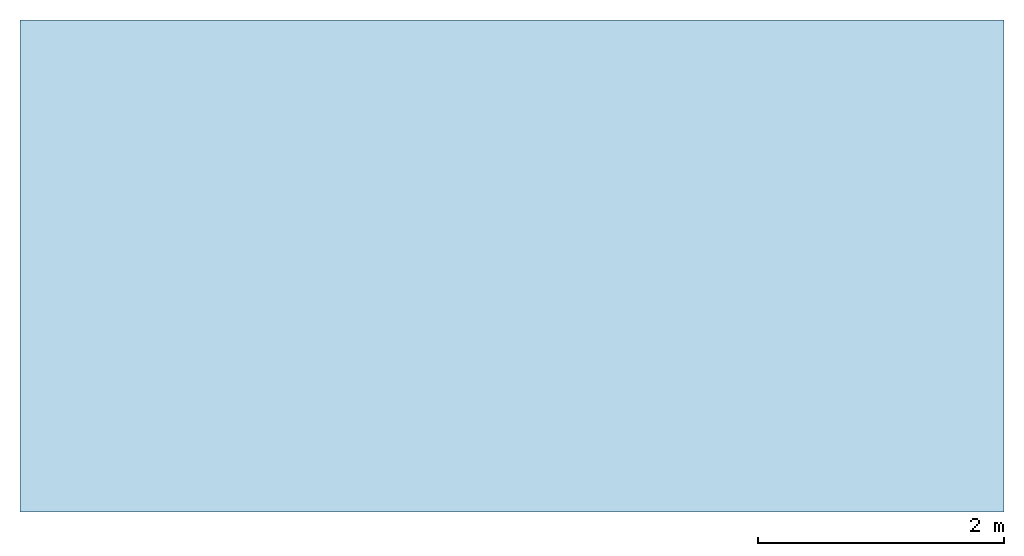
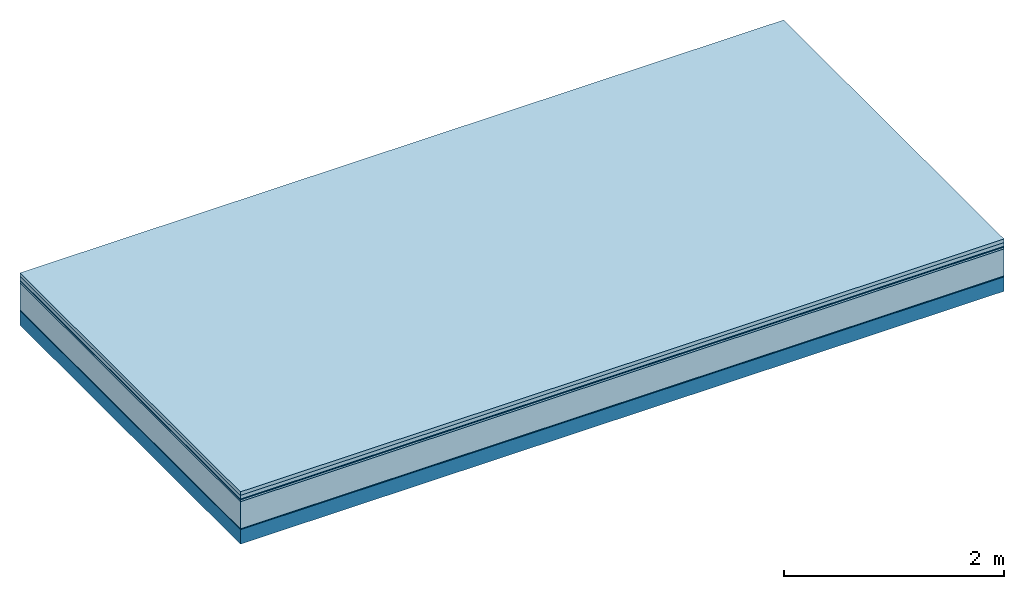
# One storey: 6 plates, 1 member, 1 element without a shape of its own.
"""IFC4 building model written with IfcOpenShell, lengths in metres."""

from ifc_helpers import new_model, si_unit, derived_unit, direction, frame, frame_2d, origin, origin_with_axes, place, context, project, spatial, rectangle, extrude, material, layer, layer_set, type_object, element, aggregate, save


model = new_model("IFC4")

# Units and contexts
plan_context = context("Plan", 3, precision=1e-05, world=origin(), true_north=direction((0.0, 1.0)))
model_context = context("Model", 3, precision=1e-05, world=origin(), true_north=direction((0.0, 1.0)))
ifc_project = project(units=[si_unit("LENGTHUNIT", "METRE"), derived_unit("SOUNDPRESSUREUNIT", [(si_unit("PRESSUREUNIT", "PASCAL", prefix="MICRO"), 0)]), si_unit("ENERGYUNIT", "JOULE", prefix="MEGA"), si_unit("MASSUNIT", "GRAM", prefix="KILO"), derived_unit("THERMALTRANSMITTANCEUNIT", [(si_unit("POWERUNIT", "WATT"), 1), (si_unit("AREAUNIT", "SQUARE_METRE"), -1), (si_unit("THERMODYNAMICTEMPERATUREUNIT", "KELVIN"), -1)]), derived_unit("AREADENSITYUNIT", [(si_unit("MASSUNIT", "GRAM", prefix="KILO"), 1), (si_unit("AREAUNIT", "SQUARE_METRE"), -1)]), derived_unit("USERDEFINED", [(si_unit("ENERGYUNIT", "JOULE", prefix="MEGA"), 1), (si_unit("AREAUNIT", "SQUARE_METRE"), -1)])], contexts=[plan_context, model_context])

# Site, building, storey
site = spatial("IfcSite", under=ifc_project)
building_placement = place(None, origin())
building = spatial("IfcBuilding", under=site, at=building_placement)
storey_placement = place(building_placement, origin())
storey = spatial("IfcBuildingStorey", under=building, at=storey_placement)

# Slab, member, plates
ifc_material_1 = material(Name="Garden plates", Category="02.007")
ifc_layer_1 = layer(ifc_material_1, 0.04, Name="Use and protection layer 3")
ifc_material_2 = material(Name="Gravel 8-16mm", Category="03.011")
ifc_layer_2 = layer(ifc_material_2, 0.04, Name="Use and protection layer 2")
ifc_material_3 = material(Name="Protective layer", Category="09.007")
ifc_layer_3 = layer(ifc_material_3, 0.01, Name="Use and protection layer 1")
ifc_material_4 = material(Name="Bituminous", Category="09.003")
ifc_layer_4 = layer(ifc_material_4, 0.02, Name="Seal")
ifc_material_5 = material(Name="Mineral wool", Category="10.008")
ifc_layer_5 = layer(ifc_material_5, 0.3, Name="Exterior insulation layer 1")
ifc_material_6 = material(Name="Vapor-permeable barrier", Category="09.006")
ifc_layer_6 = layer(ifc_material_6, 0.01, Name="layer / temporary roof")
ifc_material_7 = material(Name="no composite action")
ifc_layer_7 = layer(ifc_material_7, 0.0, Name="Bond")
ifc_layer_8 = layer(None, 0.16, Name="Support")
ifc_layer_set = layer_set([ifc_layer_1, ifc_layer_2, ifc_layer_3, ifc_layer_4, ifc_layer_5, ifc_layer_6, ifc_layer_7, ifc_layer_8])
slab_type = type_object("IfcSlabType", Name="F0051", PredefinedType="NOTDEFINED", material=ifc_layer_set)
slab_placement = place(None, frame((0.0, 0.0, 0.0), z_axis=(0.0, 0.0, -1.0), x_axis=(1.0, 0.0, 0.0)))
slab = element("IfcSlab", 1, at=slab_placement, inside=storey, type_object=slab_type, material=ifc_layer_set, Name="Slab #1")
ifc_material_8 = material(Name="Solid timber panel")
member_placement = place(slab_placement, origin())
member = element("IfcMember", 2, at=member_placement, material=ifc_material_8, Name="Support", context=plan_context, shape_type="SweptSolid", body=[
    extrude(rectangle(XDim=1.0, YDim=0.16, at=frame_2d((0.5, 0.08), x_axis=(1.0, 0.0))), frame((0.0, 4.0, 0.42), z_axis=(0.0, -1.0, 0.0), x_axis=(1.0, 0.0, 0.0)), (0.0, 0.0, 1.0), 4.0),
    extrude(rectangle(XDim=1.0, YDim=0.16, at=frame_2d((0.5, 0.08), x_axis=(1.0, 0.0))), frame((1.0, 4.0, 0.42), z_axis=(0.0, -1.0, 0.0), x_axis=(1.0, 0.0, 0.0)), (0.0, 0.0, 1.0), 4.0),
    extrude(rectangle(XDim=1.0, YDim=0.16, at=frame_2d((0.5, 0.08), x_axis=(1.0, 0.0))), frame((2.0, 4.0, 0.42), z_axis=(0.0, -1.0, 0.0), x_axis=(1.0, 0.0, 0.0)), (0.0, 0.0, 1.0), 4.0),
    extrude(rectangle(XDim=1.0, YDim=0.16, at=frame_2d((0.5, 0.08), x_axis=(1.0, 0.0))), frame((3.0, 4.0, 0.42), z_axis=(0.0, -1.0, 0.0), x_axis=(1.0, 0.0, 0.0)), (0.0, 0.0, 1.0), 4.0),
    extrude(rectangle(XDim=1.0, YDim=0.16, at=frame_2d((0.5, 0.08), x_axis=(1.0, 0.0))), frame((4.0, 4.0, 0.42), z_axis=(0.0, -1.0, 0.0), x_axis=(1.0, 0.0, 0.0)), (0.0, 0.0, 1.0), 4.0),
    extrude(rectangle(XDim=1.0, YDim=0.16, at=frame_2d((0.5, 0.08), x_axis=(1.0, 0.0))), frame((5.0, 4.0, 0.42), z_axis=(0.0, -1.0, 0.0), x_axis=(1.0, 0.0, 0.0)), (0.0, 0.0, 1.0), 4.0),
    extrude(rectangle(XDim=1.0, YDim=0.16, at=frame_2d((0.5, 0.08), x_axis=(1.0, 0.0))), frame((6.0, 4.0, 0.42), z_axis=(0.0, -1.0, 0.0), x_axis=(1.0, 0.0, 0.0)), (0.0, 0.0, 1.0), 4.0),
    extrude(rectangle(XDim=1.0, YDim=0.16, at=frame_2d((0.5, 0.08), x_axis=(1.0, 0.0))), frame((7.0, 4.0, 0.42), z_axis=(0.0, -1.0, 0.0), x_axis=(1.0, 0.0, 0.0)), (0.0, 0.0, 1.0), 4.0),
])
plate_1_placement = place(slab_placement, origin())
plate_1 = element("IfcPlate", 3, at=plate_1_placement, material=ifc_material_1, Name="Use and protection layer 3", context=plan_context, shape_type="SweptSolid", body=[
    extrude(rectangle(XDim=8.0, YDim=4.0, at=frame_2d((4.0, 2.0), x_axis=(1.0, 0.0))), origin_with_axes(), (0.0, 0.0, 1.0), 0.04),
])
plate_2_placement = place(slab_placement, origin())
plate_2 = element("IfcPlate", 4, at=plate_2_placement, material=ifc_material_2, Name="Use and protection layer 2", context=plan_context, shape_type="SweptSolid", body=[
    extrude(rectangle(XDim=8.0, YDim=4.0, at=frame_2d((4.0, 2.0), x_axis=(1.0, 0.0))), frame((0.0, 0.0, 0.04), z_axis=(0.0, 0.0, 1.0), x_axis=(1.0, 0.0, 0.0)), (0.0, 0.0, 1.0), 0.04),
])
plate_3_placement = place(slab_placement, origin())
plate_3 = element("IfcPlate", 5, at=plate_3_placement, material=ifc_material_3, Name="Use and protection layer 1", context=plan_context, shape_type="SweptSolid", body=[
    extrude(rectangle(XDim=8.0, YDim=4.0, at=frame_2d((4.0, 2.0), x_axis=(1.0, 0.0))), frame((0.0, 0.0, 0.08), z_axis=(0.0, 0.0, 1.0), x_axis=(1.0, 0.0, 0.0)), (0.0, 0.0, 1.0), 0.01),
])
plate_4_placement = place(slab_placement, origin())
plate_4 = element("IfcPlate", 6, at=plate_4_placement, material=ifc_material_4, Name="Seal", context=plan_context, shape_type="SweptSolid", body=[
    extrude(rectangle(XDim=8.0, YDim=4.0, at=frame_2d((4.0, 2.0), x_axis=(1.0, 0.0))), frame((0.0, 0.0, 0.09), z_axis=(0.0, 0.0, 1.0), x_axis=(1.0, 0.0, 0.0)), (0.0, 0.0, 1.0), 0.02),
])
plate_5_placement = place(slab_placement, origin())
plate_5 = element("IfcPlate", 7, at=plate_5_placement, material=ifc_material_5, Name="Exterior insulation layer 1", context=plan_context, shape_type="SweptSolid", body=[
    extrude(rectangle(XDim=8.0, YDim=4.0, at=frame_2d((4.0, 2.0), x_axis=(1.0, 0.0))), frame((0.0, 0.0, 0.11), z_axis=(0.0, 0.0, 1.0), x_axis=(1.0, 0.0, 0.0)), (0.0, 0.0, 1.0), 0.3),
])
plate_6_placement = place(slab_placement, origin())
plate_6 = element("IfcPlate", 8, at=plate_6_placement, material=ifc_material_6, Name="layer / temporary roof", context=plan_context, shape_type="SweptSolid", body=[
    extrude(rectangle(XDim=8.0, YDim=4.0, at=frame_2d((4.0, 2.0), x_axis=(1.0, 0.0))), frame((0.0, 0.0, 0.41), z_axis=(0.0, 0.0, 1.0), x_axis=(1.0, 0.0, 0.0)), (0.0, 0.0, 1.0), 0.01),
])
aggregate(slab, [plate_1, plate_2, plate_3, plate_4, plate_5, plate_6, member])

save(model, "model.ifc")
